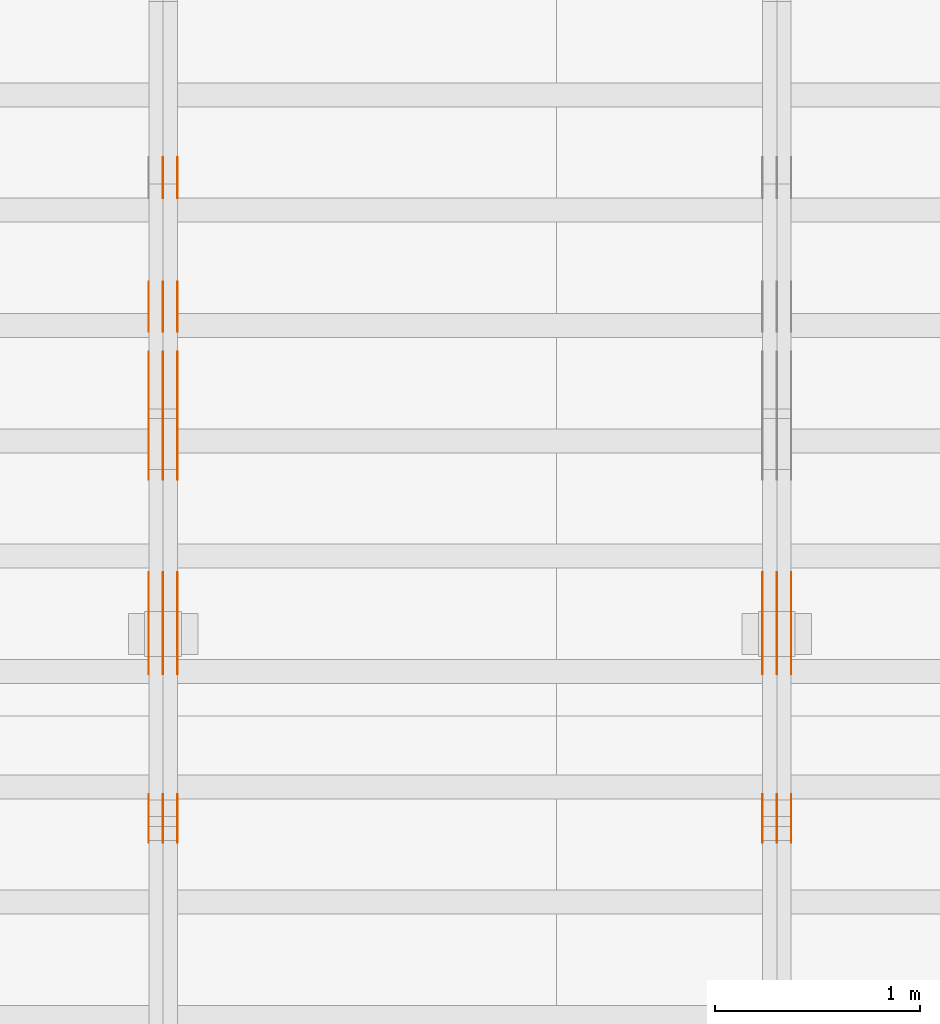
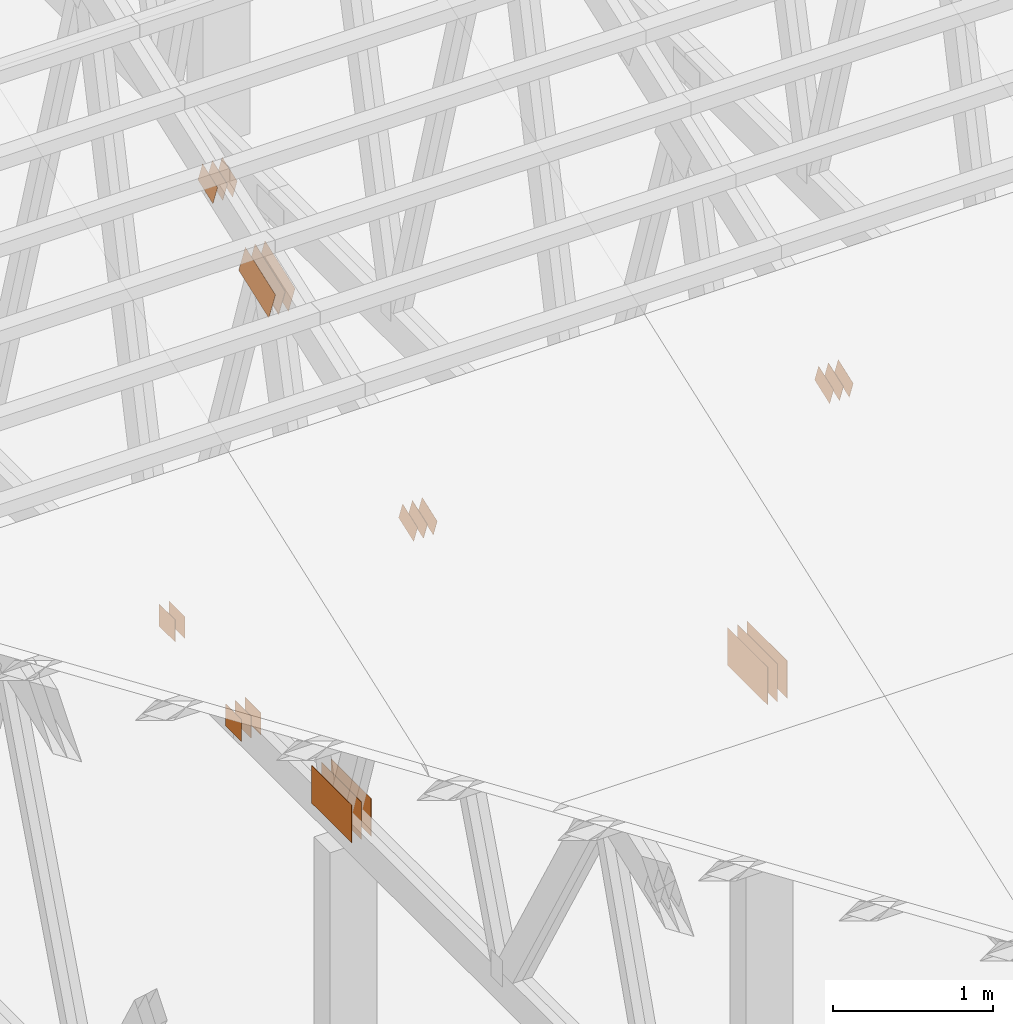
# One storey, part 95 of 189: 31 proxies.
"""IFC2X3 building model written with IfcOpenShell, lengths in millimetres."""

from ifc_helpers import new_model, entity, si_unit, converted_unit, derived_unit, direction, frame, frame_2d, origin, origin_2d_with_axis, place, context, subcontext, project, spatial, polyline, rectangle, outline, extrude, source, transform, mapped, material, type_object, type_shapes, element, save


model = new_model("IFC2X3")

# Units and contexts
model_context = context("Model", 3, precision=0.01, world=origin(), true_north=direction((6.12303176911189e-17, 1.0)))
body_context = subcontext(model_context, "Body", "Model", "MODEL_VIEW")
ifc_project = project(units=[si_unit("LENGTHUNIT", "METRE", prefix="MILLI"), si_unit("AREAUNIT", "SQUARE_METRE"), si_unit("VOLUMEUNIT", "CUBIC_METRE"), converted_unit("PLANEANGLEUNIT", "DEGREE", entity("IfcRatioMeasure", 0.0174532925199433), si_unit("PLANEANGLEUNIT", "RADIAN"), dimensions=[0, 0, 0, 0, 0, 0, 0]), si_unit("MASSUNIT", "GRAM", prefix="KILO"), derived_unit("MASSDENSITYUNIT", [(si_unit("MASSUNIT", "GRAM", prefix="KILO"), 1), (si_unit("LENGTHUNIT", "METRE"), -3)]), si_unit("TIMEUNIT", "SECOND"), si_unit("FREQUENCYUNIT", "HERTZ"), si_unit("THERMODYNAMICTEMPERATUREUNIT", "DEGREE_CELSIUS"), derived_unit("THERMALTRANSMITTANCEUNIT", [(si_unit("MASSUNIT", "GRAM", prefix="KILO"), 1), (si_unit("THERMODYNAMICTEMPERATUREUNIT", "KELVIN"), -1), (si_unit("TIMEUNIT", "SECOND"), -3)]), derived_unit("VOLUMETRICFLOWRATEUNIT", [(si_unit("LENGTHUNIT", "METRE"), 3), (si_unit("TIMEUNIT", "SECOND"), -1)]), si_unit("ELECTRICCURRENTUNIT", "AMPERE"), si_unit("ELECTRICVOLTAGEUNIT", "VOLT"), si_unit("POWERUNIT", "WATT"), si_unit("FORCEUNIT", "NEWTON"), si_unit("ILLUMINANCEUNIT", "LUX"), si_unit("LUMINOUSFLUXUNIT", "LUMEN"), si_unit("LUMINOUSINTENSITYUNIT", "CANDELA"), derived_unit("USERDEFINED", [(si_unit("MASSUNIT", "GRAM", prefix="KILO"), -1), (si_unit("LENGTHUNIT", "METRE"), -2), (si_unit("TIMEUNIT", "SECOND"), 3), (si_unit("LUMINOUSFLUXUNIT", "LUMEN"), 1)]), derived_unit("LINEARVELOCITYUNIT", [(si_unit("LENGTHUNIT", "METRE"), 1), (si_unit("TIMEUNIT", "SECOND"), -1)]), si_unit("PRESSUREUNIT", "PASCAL"), derived_unit("USERDEFINED", [(si_unit("LENGTHUNIT", "METRE"), -2), (si_unit("MASSUNIT", "GRAM", prefix="KILO"), 1), (si_unit("TIMEUNIT", "SECOND"), -2)])], contexts=[model_context])

# Site, building, storey
site_placement = place(None, origin())
site = spatial("IfcSite", under=ifc_project, at=site_placement, CompositionType="ELEMENT")
building_placement = place(site_placement, origin())
building = spatial("IfcBuilding", under=site, at=building_placement, CompositionType="ELEMENT")
storey_placement = place(building_placement, origin())
storey = spatial("IfcBuildingStorey", under=building, at=storey_placement, Name="Default", CompositionType="ELEMENT", Elevation=0.0)

# Proxies
ifc_material_1 = material(Name="IfcSurfaceStyle #107618")
building_element_proxy_type_1 = type_object("IfcBuildingElementProxyType", PredefinedType="NOTDEFINED", material=ifc_material_1)
shared_shape_1 = source(origin(), body_context, "Body", "SweptSolid", [
    extrude(rectangle(XDim=500.0, YDim=288.0, at=frame_2d((0.0, 1.4210854715202e-14), x_axis=(1.0, 0.0))), frame((250.000973740011, 144.0, 0.0), z_axis=(0.0, 0.0, 1.0), x_axis=(-1.0, 0.0, 0.0)), (0.0, 0.0, 1.0), 1.29999999999998),
])
type_shapes(building_element_proxy_type_1, [shared_shape_1])
proxy_1_placement = place(building_placement, frame((18301.3, 8551.90918250999, 389.0), z_axis=(-1.0, 0.0, 0.0), x_axis=(0.0, 1.0, 0.0)))
element("IfcBuildingElementProxy", 1, at=proxy_1_placement, inside=storey, type_object=building_element_proxy_type_1, material=ifc_material_1, context=body_context, shape_type="MappedRepresentation", body=[
    mapped(shared_shape_1, transform((0.0, 0.0, 0.0), scale=1.0)),
])
ifc_material_2 = material(Name="IfcSurfaceStyle #107561")
building_element_proxy_type_2 = type_object("IfcBuildingElementProxyType", PredefinedType="NOTDEFINED", material=ifc_material_2)
shared_shape_2 = source(origin(), body_context, "Body", "SweptSolid", [
    extrude(rectangle(XDim=500.0, YDim=288.0, at=frame_2d((0.0, 1.4210854715202e-14), x_axis=(1.0, 0.0))), frame((250.000973740011, 144.0, 0.0), z_axis=(0.0, 0.0, 1.0), x_axis=(-1.0, 0.0, 0.0)), (0.0, 0.0, 1.0), 1.29999999999997),
])
type_shapes(building_element_proxy_type_2, [shared_shape_2])
proxy_2_placement = place(building_placement, frame((18230.0, 8551.90918250999, 389.0), z_axis=(-1.0, 0.0, 0.0), x_axis=(0.0, 1.0, 0.0)))
element("IfcBuildingElementProxy", 2, at=proxy_2_placement, inside=storey, type_object=building_element_proxy_type_2, material=ifc_material_2, context=body_context, shape_type="MappedRepresentation", body=[
    mapped(shared_shape_2, transform((0.0, 0.0, 0.0), scale=1.0)),
])
ifc_material_3 = material(Name="IfcSurfaceStyle #107504")
building_element_proxy_type_3 = type_object("IfcBuildingElementProxyType", PredefinedType="NOTDEFINED", material=ifc_material_3)
shared_shape_3 = source(origin(), body_context, "Body", "SweptSolid", [
    extrude(rectangle(XDim=500.0, YDim=288.0, at=frame_2d((0.0, 1.4210854715202e-14), x_axis=(1.0, 0.0))), frame((250.000973740011, 144.0, 0.0), z_axis=(0.0, 0.0, 1.0), x_axis=(-1.0, 0.0, 0.0)), (0.0, 0.0, 1.0), 1.29999999999997),
])
type_shapes(building_element_proxy_type_3, [shared_shape_3])
proxy_3_placement = place(building_placement, frame((18231.3, 8551.90918250999, 389.0), z_axis=(-1.0, 0.0, 0.0), x_axis=(0.0, 1.0, 0.0)))
element("IfcBuildingElementProxy", 3, at=proxy_3_placement, inside=storey, type_object=building_element_proxy_type_3, material=ifc_material_3, context=body_context, shape_type="MappedRepresentation", body=[
    mapped(shared_shape_3, transform((0.0, 0.0, 0.0), scale=1.0)),
])
ifc_material_4 = material(Name="IfcSurfaceStyle #107447")
building_element_proxy_type_4 = type_object("IfcBuildingElementProxyType", PredefinedType="NOTDEFINED", material=ifc_material_4)
shared_shape_4 = source(origin(), body_context, "Body", "SweptSolid", [
    extrude(rectangle(XDim=500.0, YDim=288.0, at=frame_2d((0.0, 1.4210854715202e-14), x_axis=(1.0, 0.0))), frame((250.000973740011, 144.0, 0.0), z_axis=(0.0, 0.0, 1.0), x_axis=(-1.0, 0.0, 0.0)), (0.0, 0.0, 1.0), 1.29999999999997),
])
type_shapes(building_element_proxy_type_4, [shared_shape_4])
proxy_4_placement = place(building_placement, frame((18160.0, 8551.90918250999, 389.0), z_axis=(-1.0, 0.0, 0.0), x_axis=(0.0, 1.0, 0.0)))
element("IfcBuildingElementProxy", 4, at=proxy_4_placement, inside=storey, type_object=building_element_proxy_type_4, material=ifc_material_4, context=body_context, shape_type="MappedRepresentation", body=[
    mapped(shared_shape_4, transform((0.0, 0.0, 0.0), scale=1.0)),
])
ifc_material_5 = material(Name="IfcSurfaceStyle #107390")
building_element_proxy_type_5 = type_object("IfcBuildingElementProxyType", PredefinedType="NOTDEFINED", material=ifc_material_5)
shared_shape_5 = source(origin(), body_context, "Body", "SweptSolid", [
    extrude(outline(polyline([(-100.00048713087, -72.0000025659129), (100.000394045495, -72.0000025659129), (99.9995694622958, 72.0000025659129), (-99.9994763769209, 72.0000025659128), (-100.00048713087, -72.0000025659129)])), frame((100.000394045495, 72.0000025659128, 0.0), z_axis=(0.0, 0.0, 1.0), x_axis=(-1.0, 0.0, 0.0)), (0.0, 0.0, 1.0), 1.3),
])
type_shapes(building_element_proxy_type_5, [shared_shape_5])
proxy_5_placement = place(building_placement, frame((18301.3, 7965.16887114408, 2936.19963864386), z_axis=(-1.0, 0.0, 0.0), x_axis=(0.0, -0.939692620785908, -0.342020143325669)))
element("IfcBuildingElementProxy", 5, at=proxy_5_placement, inside=storey, type_object=building_element_proxy_type_5, material=ifc_material_5, context=body_context, shape_type="MappedRepresentation", body=[
    mapped(shared_shape_5, transform((0.0, 0.0, 0.0), scale=1.0)),
])
ifc_material_6 = material(Name="IfcSurfaceStyle #107333")
building_element_proxy_type_6 = type_object("IfcBuildingElementProxyType", PredefinedType="NOTDEFINED", material=ifc_material_6)
shared_shape_6 = source(origin(), body_context, "Body", "SweptSolid", [
    extrude(outline(polyline([(-100.00048713087, -72.0000025659129), (100.000394045495, -72.0000025659129), (99.9995694622958, 72.0000025659129), (-99.9994763769209, 72.0000025659128), (-100.00048713087, -72.0000025659129)])), frame((100.000394045495, 72.0000025659128, 0.0), z_axis=(0.0, 0.0, 1.0), x_axis=(-1.0, 0.0, 0.0)), (0.0, 0.0, 1.0), 1.29999999999998),
])
type_shapes(building_element_proxy_type_6, [shared_shape_6])
proxy_6_placement = place(building_placement, frame((18230.0, 7965.16887114408, 2936.19963864386), z_axis=(-1.0, 0.0, 0.0), x_axis=(0.0, -0.939692620785908, -0.342020143325669)))
element("IfcBuildingElementProxy", 6, at=proxy_6_placement, inside=storey, type_object=building_element_proxy_type_6, material=ifc_material_6, context=body_context, shape_type="MappedRepresentation", body=[
    mapped(shared_shape_6, transform((0.0, 0.0, 0.0), scale=1.0)),
])
ifc_material_7 = material(Name="IfcSurfaceStyle #107276")
building_element_proxy_type_7 = type_object("IfcBuildingElementProxyType", PredefinedType="NOTDEFINED", material=ifc_material_7)
shared_shape_7 = source(origin(), body_context, "Body", "SweptSolid", [
    extrude(outline(polyline([(-100.00048713087, -72.0000025659129), (100.000394045495, -72.0000025659129), (99.9995694622958, 72.0000025659129), (-99.9994763769209, 72.0000025659128), (-100.00048713087, -72.0000025659129)])), frame((100.000394045495, 72.0000025659128, 0.0), z_axis=(0.0, 0.0, 1.0), x_axis=(-1.0, 0.0, 0.0)), (0.0, 0.0, 1.0), 1.29999999999998),
])
type_shapes(building_element_proxy_type_7, [shared_shape_7])
proxy_7_placement = place(building_placement, frame((18231.3, 7965.16887114408, 2936.19963864386), z_axis=(-1.0, 0.0, 0.0), x_axis=(0.0, -0.939692620785908, -0.342020143325669)))
element("IfcBuildingElementProxy", 7, at=proxy_7_placement, inside=storey, type_object=building_element_proxy_type_7, material=ifc_material_7, context=body_context, shape_type="MappedRepresentation", body=[
    mapped(shared_shape_7, transform((0.0, 0.0, 0.0), scale=1.0)),
])
ifc_material_8 = material(Name="IfcSurfaceStyle #107219")
building_element_proxy_type_8 = type_object("IfcBuildingElementProxyType", PredefinedType="NOTDEFINED", material=ifc_material_8)
shared_shape_8 = source(origin(), body_context, "Body", "SweptSolid", [
    extrude(outline(polyline([(-100.00048713087, -72.0000025659129), (100.000394045495, -72.0000025659129), (99.9995694622958, 72.0000025659129), (-99.9994763769209, 72.0000025659128), (-100.00048713087, -72.0000025659129)])), frame((100.000394045495, 72.0000025659128, 0.0), z_axis=(0.0, 0.0, 1.0), x_axis=(-1.0, 0.0, 0.0)), (0.0, 0.0, 1.0), 1.29999999999999),
])
type_shapes(building_element_proxy_type_8, [shared_shape_8])
proxy_8_placement = place(building_placement, frame((18160.0, 7965.16887114408, 2936.19963864386), z_axis=(-1.0, 0.0, 0.0), x_axis=(0.0, -0.939692620785908, -0.342020143325669)))
element("IfcBuildingElementProxy", 8, at=proxy_8_placement, inside=storey, type_object=building_element_proxy_type_8, material=ifc_material_8, context=body_context, shape_type="MappedRepresentation", body=[
    mapped(shared_shape_8, transform((0.0, 0.0, 0.0), scale=1.0)),
])
ifc_material_9 = material(Name="IfcSurfaceStyle #92740")
building_element_proxy_type_9 = type_object("IfcBuildingElementProxyType", PredefinedType="NOTDEFINED", material=ifc_material_9)
shared_shape_9 = source(origin(), body_context, "Body", "SweptSolid", [
    extrude(rectangle(XDim=200.0, YDim=168.0, at=origin_2d_with_axis()), frame((100.000765376775, 84.0, 0.0), z_axis=(0.0, 0.0, 1.0), x_axis=(-1.0, 0.0, 0.0)), (0.0, 0.0, 1.0), 1.3),
])
type_shapes(building_element_proxy_type_9, [shared_shape_9])
proxy_9_placement = place(building_placement, frame((15301.3, 10880.1574377482, 365.0), z_axis=(-1.0, 0.0, 0.0), x_axis=(0.0, 1.0, 0.0)))
element("IfcBuildingElementProxy", 9, at=proxy_9_placement, inside=storey, type_object=building_element_proxy_type_9, material=ifc_material_9, context=body_context, shape_type="MappedRepresentation", body=[
    mapped(shared_shape_9, transform((0.0, 0.0, 0.0), scale=1.0)),
])
ifc_material_10 = material(Name="IfcSurfaceStyle #92683")
building_element_proxy_type_10 = type_object("IfcBuildingElementProxyType", PredefinedType="NOTDEFINED", material=ifc_material_10)
shared_shape_10 = source(origin(), body_context, "Body", "SweptSolid", [
    extrude(rectangle(XDim=200.0, YDim=168.0, at=origin_2d_with_axis()), frame((100.000765376775, 84.0, 0.0), z_axis=(0.0, 0.0, 1.0), x_axis=(-1.0, 0.0, 0.0)), (0.0, 0.0, 1.0), 1.29999999999998),
])
type_shapes(building_element_proxy_type_10, [shared_shape_10])
proxy_10_placement = place(building_placement, frame((15230.0, 10880.1574377482, 365.0), z_axis=(-1.0, 0.0, 0.0), x_axis=(0.0, 1.0, 0.0)))
element("IfcBuildingElementProxy", 10, at=proxy_10_placement, inside=storey, type_object=building_element_proxy_type_10, material=ifc_material_10, context=body_context, shape_type="MappedRepresentation", body=[
    mapped(shared_shape_10, transform((0.0, 0.0, 0.0), scale=1.0)),
])
ifc_material_11 = material(Name="IfcSurfaceStyle #92626")
building_element_proxy_type_11 = type_object("IfcBuildingElementProxyType", PredefinedType="NOTDEFINED", material=ifc_material_11)
shared_shape_11 = source(origin(), body_context, "Body", "SweptSolid", [
    extrude(rectangle(XDim=200.0, YDim=168.0, at=origin_2d_with_axis()), frame((100.000765376775, 84.0, 0.0), z_axis=(0.0, 0.0, 1.0), x_axis=(-1.0, 0.0, 0.0)), (0.0, 0.0, 1.0), 1.29999999999998),
])
type_shapes(building_element_proxy_type_11, [shared_shape_11])
proxy_11_placement = place(building_placement, frame((15231.3, 10880.1574377482, 365.0), z_axis=(-1.0, 0.0, 0.0), x_axis=(0.0, 1.0, 0.0)))
element("IfcBuildingElementProxy", 11, at=proxy_11_placement, inside=storey, type_object=building_element_proxy_type_11, material=ifc_material_11, context=body_context, shape_type="MappedRepresentation", body=[
    mapped(shared_shape_11, transform((0.0, 0.0, 0.0), scale=1.0)),
])
ifc_material_12 = material(Name="IfcSurfaceStyle #92512")
building_element_proxy_type_12 = type_object("IfcBuildingElementProxyType", PredefinedType="NOTDEFINED", material=ifc_material_12)
shared_shape_12 = source(origin(), body_context, "Body", "SweptSolid", [
    extrude(outline(polyline([(-199.999582244654, -119.99984375717), (200.000344770932, -119.99984375717), (199.999582244655, 119.99984375717), (-200.000344770934, 119.99984375717), (-199.999582244654, -119.99984375717)])), frame((200.000344770932, 120.0000091947, 0.0), z_axis=(0.0, 0.0, 1.0), x_axis=(-1.0, 0.0, 0.0)), (0.0, 0.0, 1.0), 1.29999999999999),
])
type_shapes(building_element_proxy_type_12, [shared_shape_12])
proxy_12_placement = place(building_placement, frame((15301.3, 9961.90704972973, 3612.2451494258), z_axis=(-1.0, 0.0, 0.0), x_axis=(0.0, -0.939692620785908, -0.342020143325669)))
element("IfcBuildingElementProxy", 12, at=proxy_12_placement, inside=storey, type_object=building_element_proxy_type_12, material=ifc_material_12, context=body_context, shape_type="MappedRepresentation", body=[
    mapped(shared_shape_12, transform((0.0, 0.0, 0.0), scale=1.0)),
])
ifc_material_13 = material(Name="IfcSurfaceStyle #92455")
building_element_proxy_type_13 = type_object("IfcBuildingElementProxyType", PredefinedType="NOTDEFINED", material=ifc_material_13)
shared_shape_13 = source(origin(), body_context, "Body", "SweptSolid", [
    extrude(outline(polyline([(-199.999582244654, -119.99984375717), (200.000344770932, -119.99984375717), (199.999582244655, 119.99984375717), (-200.000344770934, 119.99984375717), (-199.999582244654, -119.99984375717)])), frame((200.000344770932, 120.0000091947, 0.0), z_axis=(0.0, 0.0, 1.0), x_axis=(-1.0, 0.0, 0.0)), (0.0, 0.0, 1.0), 1.29999999999997),
])
type_shapes(building_element_proxy_type_13, [shared_shape_13])
proxy_13_placement = place(building_placement, frame((15230.0, 9961.90704972973, 3612.2451494258), z_axis=(-1.0, 0.0, 0.0), x_axis=(0.0, -0.939692620785908, -0.342020143325669)))
element("IfcBuildingElementProxy", 13, at=proxy_13_placement, inside=storey, type_object=building_element_proxy_type_13, material=ifc_material_13, context=body_context, shape_type="MappedRepresentation", body=[
    mapped(shared_shape_13, transform((0.0, 0.0, 0.0), scale=1.0)),
])
ifc_material_14 = material(Name="IfcSurfaceStyle #92398")
building_element_proxy_type_14 = type_object("IfcBuildingElementProxyType", PredefinedType="NOTDEFINED", material=ifc_material_14)
shared_shape_14 = source(origin(), body_context, "Body", "SweptSolid", [
    extrude(outline(polyline([(-199.999582244654, -119.99984375717), (200.000344770932, -119.99984375717), (199.999582244655, 119.99984375717), (-200.000344770934, 119.99984375717), (-199.999582244654, -119.99984375717)])), frame((200.000344770932, 120.0000091947, 0.0), z_axis=(0.0, 0.0, 1.0), x_axis=(-1.0, 0.0, 0.0)), (0.0, 0.0, 1.0), 1.29999999999997),
])
type_shapes(building_element_proxy_type_14, [shared_shape_14])
proxy_14_placement = place(building_placement, frame((15231.3, 9961.90704972973, 3612.2451494258), z_axis=(-1.0, 0.0, 0.0), x_axis=(0.0, -0.939692620785908, -0.342020143325669)))
element("IfcBuildingElementProxy", 14, at=proxy_14_placement, inside=storey, type_object=building_element_proxy_type_14, material=ifc_material_14, context=body_context, shape_type="MappedRepresentation", body=[
    mapped(shared_shape_14, transform((0.0, 0.0, 0.0), scale=1.0)),
])
ifc_material_15 = material(Name="IfcSurfaceStyle #92341")
building_element_proxy_type_15 = type_object("IfcBuildingElementProxyType", PredefinedType="NOTDEFINED", material=ifc_material_15)
shared_shape_15 = source(origin(), body_context, "Body", "SweptSolid", [
    extrude(outline(polyline([(-199.999582244654, -119.99984375717), (200.000344770932, -119.99984375717), (199.999582244655, 119.99984375717), (-200.000344770934, 119.99984375717), (-199.999582244654, -119.99984375717)])), frame((200.000344770932, 120.0000091947, 0.0), z_axis=(0.0, 0.0, 1.0), x_axis=(-1.0, 0.0, 0.0)), (0.0, 0.0, 1.0), 1.29999999999998),
])
type_shapes(building_element_proxy_type_15, [shared_shape_15])
proxy_15_placement = place(building_placement, frame((15160.0, 9961.90704972973, 3612.2451494258), z_axis=(-1.0, 0.0, 0.0), x_axis=(0.0, -0.939692620785908, -0.342020143325669)))
element("IfcBuildingElementProxy", 15, at=proxy_15_placement, inside=storey, type_object=building_element_proxy_type_15, material=ifc_material_15, context=body_context, shape_type="MappedRepresentation", body=[
    mapped(shared_shape_15, transform((0.0, 0.0, 0.0), scale=1.0)),
])
ifc_material_16 = material(Name="IfcSurfaceStyle #91828")
building_element_proxy_type_16 = type_object("IfcBuildingElementProxyType", PredefinedType="NOTDEFINED", material=ifc_material_16)
shared_shape_16 = source(origin(), body_context, "Body", "SweptSolid", [
    extrude(rectangle(XDim=500.0, YDim=288.0, at=frame_2d((0.0, 1.4210854715202e-14), x_axis=(1.0, 0.0))), frame((250.000973740011, 144.0, 0.0), z_axis=(0.0, 0.0, 1.0), x_axis=(-1.0, 0.0, 0.0)), (0.0, 0.0, 1.0), 1.29999999999998),
])
type_shapes(building_element_proxy_type_16, [shared_shape_16])
proxy_16_placement = place(building_placement, frame((15301.3, 8551.90918250999, 389.0), z_axis=(-1.0, 0.0, 0.0), x_axis=(0.0, 1.0, 0.0)))
element("IfcBuildingElementProxy", 16, at=proxy_16_placement, inside=storey, type_object=building_element_proxy_type_16, material=ifc_material_16, context=body_context, shape_type="MappedRepresentation", body=[
    mapped(shared_shape_16, transform((0.0, 0.0, 0.0), scale=1.0)),
])
ifc_material_17 = material(Name="IfcSurfaceStyle #91771")
building_element_proxy_type_17 = type_object("IfcBuildingElementProxyType", PredefinedType="NOTDEFINED", material=ifc_material_17)
shared_shape_17 = source(origin(), body_context, "Body", "SweptSolid", [
    extrude(rectangle(XDim=500.0, YDim=288.0, at=frame_2d((0.0, 1.4210854715202e-14), x_axis=(1.0, 0.0))), frame((250.000973740011, 144.0, 0.0), z_axis=(0.0, 0.0, 1.0), x_axis=(-1.0, 0.0, 0.0)), (0.0, 0.0, 1.0), 1.29999999999997),
])
type_shapes(building_element_proxy_type_17, [shared_shape_17])
proxy_17_placement = place(building_placement, frame((15230.0, 8551.90918250999, 389.0), z_axis=(-1.0, 0.0, 0.0), x_axis=(0.0, 1.0, 0.0)))
element("IfcBuildingElementProxy", 17, at=proxy_17_placement, inside=storey, type_object=building_element_proxy_type_17, material=ifc_material_17, context=body_context, shape_type="MappedRepresentation", body=[
    mapped(shared_shape_17, transform((0.0, 0.0, 0.0), scale=1.0)),
])
ifc_material_18 = material(Name="IfcSurfaceStyle #91714")
building_element_proxy_type_18 = type_object("IfcBuildingElementProxyType", PredefinedType="NOTDEFINED", material=ifc_material_18)
shared_shape_18 = source(origin(), body_context, "Body", "SweptSolid", [
    extrude(rectangle(XDim=500.0, YDim=288.0, at=frame_2d((0.0, 1.4210854715202e-14), x_axis=(1.0, 0.0))), frame((250.000973740011, 144.0, 0.0), z_axis=(0.0, 0.0, 1.0), x_axis=(-1.0, 0.0, 0.0)), (0.0, 0.0, 1.0), 1.29999999999997),
])
type_shapes(building_element_proxy_type_18, [shared_shape_18])
proxy_18_placement = place(building_placement, frame((15231.3, 8551.90918250999, 389.0), z_axis=(-1.0, 0.0, 0.0), x_axis=(0.0, 1.0, 0.0)))
element("IfcBuildingElementProxy", 18, at=proxy_18_placement, inside=storey, type_object=building_element_proxy_type_18, material=ifc_material_18, context=body_context, shape_type="MappedRepresentation", body=[
    mapped(shared_shape_18, transform((0.0, 0.0, 0.0), scale=1.0)),
])
ifc_material_19 = material(Name="IfcSurfaceStyle #91657")
building_element_proxy_type_19 = type_object("IfcBuildingElementProxyType", PredefinedType="NOTDEFINED", material=ifc_material_19)
shared_shape_19 = source(origin(), body_context, "Body", "SweptSolid", [
    extrude(rectangle(XDim=500.0, YDim=288.0, at=frame_2d((0.0, 1.4210854715202e-14), x_axis=(1.0, 0.0))), frame((250.000973740011, 144.0, 0.0), z_axis=(0.0, 0.0, 1.0), x_axis=(-1.0, 0.0, 0.0)), (0.0, 0.0, 1.0), 1.29999999999997),
])
type_shapes(building_element_proxy_type_19, [shared_shape_19])
proxy_19_placement = place(building_placement, frame((15160.0, 8551.90918250999, 389.0), z_axis=(-1.0, 0.0, 0.0), x_axis=(0.0, 1.0, 0.0)))
element("IfcBuildingElementProxy", 19, at=proxy_19_placement, inside=storey, type_object=building_element_proxy_type_19, material=ifc_material_19, context=body_context, shape_type="MappedRepresentation", body=[
    mapped(shared_shape_19, transform((0.0, 0.0, 0.0), scale=1.0)),
])
ifc_material_20 = material(Name="IfcSurfaceStyle #91600")
building_element_proxy_type_20 = type_object("IfcBuildingElementProxyType", PredefinedType="NOTDEFINED", material=ifc_material_20)
shared_shape_20 = source(origin(), body_context, "Body", "SweptSolid", [
    extrude(outline(polyline([(-100.00048713087, -72.0000025659129), (100.000394045495, -72.0000025659129), (99.9995694622958, 72.0000025659129), (-99.9994763769209, 72.0000025659128), (-100.00048713087, -72.0000025659129)])), frame((100.000394045495, 72.0000025659128, 0.0), z_axis=(0.0, 0.0, 1.0), x_axis=(-1.0, 0.0, 0.0)), (0.0, 0.0, 1.0), 1.3),
])
type_shapes(building_element_proxy_type_20, [shared_shape_20])
proxy_20_placement = place(building_placement, frame((15301.3, 7965.16887114408, 2936.19963864386), z_axis=(-1.0, 0.0, 0.0), x_axis=(0.0, -0.939692620785908, -0.342020143325669)))
element("IfcBuildingElementProxy", 20, at=proxy_20_placement, inside=storey, type_object=building_element_proxy_type_20, material=ifc_material_20, context=body_context, shape_type="MappedRepresentation", body=[
    mapped(shared_shape_20, transform((0.0, 0.0, 0.0), scale=1.0)),
])
ifc_material_21 = material(Name="IfcSurfaceStyle #91543")
building_element_proxy_type_21 = type_object("IfcBuildingElementProxyType", PredefinedType="NOTDEFINED", material=ifc_material_21)
shared_shape_21 = source(origin(), body_context, "Body", "SweptSolid", [
    extrude(outline(polyline([(-100.00048713087, -72.0000025659129), (100.000394045495, -72.0000025659129), (99.9995694622958, 72.0000025659129), (-99.9994763769209, 72.0000025659128), (-100.00048713087, -72.0000025659129)])), frame((100.000394045495, 72.0000025659128, 0.0), z_axis=(0.0, 0.0, 1.0), x_axis=(-1.0, 0.0, 0.0)), (0.0, 0.0, 1.0), 1.29999999999998),
])
type_shapes(building_element_proxy_type_21, [shared_shape_21])
proxy_21_placement = place(building_placement, frame((15230.0, 7965.16887114408, 2936.19963864386), z_axis=(-1.0, 0.0, 0.0), x_axis=(0.0, -0.939692620785908, -0.342020143325669)))
element("IfcBuildingElementProxy", 21, at=proxy_21_placement, inside=storey, type_object=building_element_proxy_type_21, material=ifc_material_21, context=body_context, shape_type="MappedRepresentation", body=[
    mapped(shared_shape_21, transform((0.0, 0.0, 0.0), scale=1.0)),
])
ifc_material_22 = material(Name="IfcSurfaceStyle #91486")
building_element_proxy_type_22 = type_object("IfcBuildingElementProxyType", PredefinedType="NOTDEFINED", material=ifc_material_22)
shared_shape_22 = source(origin(), body_context, "Body", "SweptSolid", [
    extrude(outline(polyline([(-100.00048713087, -72.0000025659129), (100.000394045495, -72.0000025659129), (99.9995694622958, 72.0000025659129), (-99.9994763769209, 72.0000025659128), (-100.00048713087, -72.0000025659129)])), frame((100.000394045495, 72.0000025659128, 0.0), z_axis=(0.0, 0.0, 1.0), x_axis=(-1.0, 0.0, 0.0)), (0.0, 0.0, 1.0), 1.29999999999998),
])
type_shapes(building_element_proxy_type_22, [shared_shape_22])
proxy_22_placement = place(building_placement, frame((15231.3, 7965.16887114408, 2936.19963864386), z_axis=(-1.0, 0.0, 0.0), x_axis=(0.0, -0.939692620785908, -0.342020143325669)))
element("IfcBuildingElementProxy", 22, at=proxy_22_placement, inside=storey, type_object=building_element_proxy_type_22, material=ifc_material_22, context=body_context, shape_type="MappedRepresentation", body=[
    mapped(shared_shape_22, transform((0.0, 0.0, 0.0), scale=1.0)),
])
ifc_material_23 = material(Name="IfcSurfaceStyle #91429")
building_element_proxy_type_23 = type_object("IfcBuildingElementProxyType", PredefinedType="NOTDEFINED", material=ifc_material_23)
shared_shape_23 = source(origin(), body_context, "Body", "SweptSolid", [
    extrude(outline(polyline([(-100.00048713087, -72.0000025659129), (100.000394045495, -72.0000025659129), (99.9995694622958, 72.0000025659129), (-99.9994763769209, 72.0000025659128), (-100.00048713087, -72.0000025659129)])), frame((100.000394045495, 72.0000025659128, 0.0), z_axis=(0.0, 0.0, 1.0), x_axis=(-1.0, 0.0, 0.0)), (0.0, 0.0, 1.0), 1.29999999999999),
])
type_shapes(building_element_proxy_type_23, [shared_shape_23])
proxy_23_placement = place(building_placement, frame((15160.0, 7965.16887114408, 2936.19963864386), z_axis=(-1.0, 0.0, 0.0), x_axis=(0.0, -0.939692620785908, -0.342020143325669)))
element("IfcBuildingElementProxy", 23, at=proxy_23_placement, inside=storey, type_object=building_element_proxy_type_23, material=ifc_material_23, context=body_context, shape_type="MappedRepresentation", body=[
    mapped(shared_shape_23, transform((0.0, 0.0, 0.0), scale=1.0)),
])
ifc_material_24 = material(Name="IfcSurfaceStyle #86188")
building_element_proxy_type_24 = type_object("IfcBuildingElementProxyType", PredefinedType="NOTDEFINED", material=ifc_material_24)
shared_shape_24 = source(origin(), body_context, "Body", "SweptSolid", [
    extrude(rectangle(XDim=200.0, YDim=168.0, at=origin_2d_with_axis()), frame((100.0, 84.0, 0.0), z_axis=(0.0, 0.0, 1.0), x_axis=(-1.0, 0.0, 0.0)), (0.0, 0.0, 1.0), 1.3),
])
type_shapes(building_element_proxy_type_24, [shared_shape_24])
proxy_24_placement = place(building_placement, frame((15301.3, 9929.23046875, 206.5), z_axis=(-1.0, 0.0, 0.0), x_axis=(0.0, 1.0, 0.0)))
element("IfcBuildingElementProxy", 24, at=proxy_24_placement, inside=storey, type_object=building_element_proxy_type_24, material=ifc_material_24, context=body_context, shape_type="MappedRepresentation", body=[
    mapped(shared_shape_24, transform((0.0, 0.0, 0.0), scale=1.0)),
])
ifc_material_25 = material(Name="IfcSurfaceStyle #86131")
building_element_proxy_type_25 = type_object("IfcBuildingElementProxyType", PredefinedType="NOTDEFINED", material=ifc_material_25)
shared_shape_25 = source(origin(), body_context, "Body", "SweptSolid", [
    extrude(rectangle(XDim=200.0, YDim=168.0, at=origin_2d_with_axis()), frame((100.0, 84.0, 0.0), z_axis=(0.0, 0.0, 1.0), x_axis=(-1.0, 0.0, 0.0)), (0.0, 0.0, 1.0), 1.29999999999998),
])
type_shapes(building_element_proxy_type_25, [shared_shape_25])
proxy_25_placement = place(building_placement, frame((15230.0, 9929.23046875, 206.5), z_axis=(-1.0, 0.0, 0.0), x_axis=(0.0, 1.0, 0.0)))
element("IfcBuildingElementProxy", 25, at=proxy_25_placement, inside=storey, type_object=building_element_proxy_type_25, material=ifc_material_25, context=body_context, shape_type="MappedRepresentation", body=[
    mapped(shared_shape_25, transform((0.0, 0.0, 0.0), scale=1.0)),
])
ifc_material_26 = material(Name="IfcSurfaceStyle #86074")
building_element_proxy_type_26 = type_object("IfcBuildingElementProxyType", PredefinedType="NOTDEFINED", material=ifc_material_26)
shared_shape_26 = source(origin(), body_context, "Body", "SweptSolid", [
    extrude(rectangle(XDim=200.0, YDim=168.0, at=origin_2d_with_axis()), frame((100.0, 84.0, 0.0), z_axis=(0.0, 0.0, 1.0), x_axis=(-1.0, 0.0, 0.0)), (0.0, 0.0, 1.0), 1.29999999999998),
])
type_shapes(building_element_proxy_type_26, [shared_shape_26])
proxy_26_placement = place(building_placement, frame((15231.3, 9929.23046875, 206.5), z_axis=(-1.0, 0.0, 0.0), x_axis=(0.0, 1.0, 0.0)))
element("IfcBuildingElementProxy", 26, at=proxy_26_placement, inside=storey, type_object=building_element_proxy_type_26, material=ifc_material_26, context=body_context, shape_type="MappedRepresentation", body=[
    mapped(shared_shape_26, transform((0.0, 0.0, 0.0), scale=1.0)),
])
ifc_material_27 = material(Name="IfcSurfaceStyle #86017")
building_element_proxy_type_27 = type_object("IfcBuildingElementProxyType", PredefinedType="NOTDEFINED", material=ifc_material_27)
shared_shape_27 = source(origin(), body_context, "Body", "SweptSolid", [
    extrude(rectangle(XDim=200.0, YDim=168.0, at=origin_2d_with_axis()), frame((100.0, 84.0, 0.0), z_axis=(0.0, 0.0, 1.0), x_axis=(-1.0, 0.0, 0.0)), (0.0, 0.0, 1.0), 1.29999999999999),
])
type_shapes(building_element_proxy_type_27, [shared_shape_27])
proxy_27_placement = place(building_placement, frame((15160.0, 9929.23046875, 206.5), z_axis=(-1.0, 0.0, 0.0), x_axis=(0.0, 1.0, 0.0)))
element("IfcBuildingElementProxy", 27, at=proxy_27_placement, inside=storey, type_object=building_element_proxy_type_27, material=ifc_material_27, context=body_context, shape_type="MappedRepresentation", body=[
    mapped(shared_shape_27, transform((0.0, 0.0, 0.0), scale=1.0)),
])
ifc_material_28 = material(Name="IfcSurfaceStyle #85108")
building_element_proxy_type_28 = type_object("IfcBuildingElementProxyType", PredefinedType="NOTDEFINED", material=ifc_material_28)
shared_shape_28 = source(origin(), body_context, "Body", "SweptSolid", [
    extrude(outline(polyline([(-100.00072430513, -84.0000258989549), (100.000156871239, -84.0000258989549), (99.9997648860508, 84.0000258989549), (-99.9991974521591, 84.0000258989548), (-100.00072430513, -84.0000258989549)])), frame((100.000156871239, 84.0000258989548, 0.0), z_axis=(0.0, 0.0, 1.0), x_axis=(-1.0, 0.0, 0.0)), (0.0, 0.0, 1.0), 1.3),
])
type_shapes(building_element_proxy_type_28, [shared_shape_28])
proxy_28_placement = place(building_placement, frame((15301.3, 10226.4409888304, 4081.14941482552), z_axis=(-1.0, 0.0, 0.0), x_axis=(0.0, 0.939692620785908, 0.342020143325669)))
element("IfcBuildingElementProxy", 28, at=proxy_28_placement, inside=storey, type_object=building_element_proxy_type_28, material=ifc_material_28, context=body_context, shape_type="MappedRepresentation", body=[
    mapped(shared_shape_28, transform((0.0, 0.0, 0.0), scale=1.0)),
])
ifc_material_29 = material(Name="IfcSurfaceStyle #85051")
building_element_proxy_type_29 = type_object("IfcBuildingElementProxyType", PredefinedType="NOTDEFINED", material=ifc_material_29)
shared_shape_29 = source(origin(), body_context, "Body", "SweptSolid", [
    extrude(outline(polyline([(-100.00072430513, -84.0000258989549), (100.000156871239, -84.0000258989549), (99.9997648860508, 84.0000258989549), (-99.9991974521591, 84.0000258989548), (-100.00072430513, -84.0000258989549)])), frame((100.000156871239, 84.0000258989548, 0.0), z_axis=(0.0, 0.0, 1.0), x_axis=(-1.0, 0.0, 0.0)), (0.0, 0.0, 1.0), 1.29999999999998),
])
type_shapes(building_element_proxy_type_29, [shared_shape_29])
proxy_29_placement = place(building_placement, frame((15230.0, 10226.4409888304, 4081.14941482552), z_axis=(-1.0, 0.0, 0.0), x_axis=(0.0, 0.939692620785908, 0.342020143325669)))
element("IfcBuildingElementProxy", 29, at=proxy_29_placement, inside=storey, type_object=building_element_proxy_type_29, material=ifc_material_29, context=body_context, shape_type="MappedRepresentation", body=[
    mapped(shared_shape_29, transform((0.0, 0.0, 0.0), scale=1.0)),
])
ifc_material_30 = material(Name="IfcSurfaceStyle #84994")
building_element_proxy_type_30 = type_object("IfcBuildingElementProxyType", PredefinedType="NOTDEFINED", material=ifc_material_30)
shared_shape_30 = source(origin(), body_context, "Body", "SweptSolid", [
    extrude(outline(polyline([(-100.00072430513, -84.0000258989549), (100.000156871239, -84.0000258989549), (99.9997648860508, 84.0000258989549), (-99.9991974521591, 84.0000258989548), (-100.00072430513, -84.0000258989549)])), frame((100.000156871239, 84.0000258989548, 0.0), z_axis=(0.0, 0.0, 1.0), x_axis=(-1.0, 0.0, 0.0)), (0.0, 0.0, 1.0), 1.29999999999998),
])
type_shapes(building_element_proxy_type_30, [shared_shape_30])
proxy_30_placement = place(building_placement, frame((15231.3, 10226.4409888304, 4081.14941482552), z_axis=(-1.0, 0.0, 0.0), x_axis=(0.0, 0.939692620785908, 0.342020143325669)))
element("IfcBuildingElementProxy", 30, at=proxy_30_placement, inside=storey, type_object=building_element_proxy_type_30, material=ifc_material_30, context=body_context, shape_type="MappedRepresentation", body=[
    mapped(shared_shape_30, transform((0.0, 0.0, 0.0), scale=1.0)),
])
ifc_material_31 = material(Name="IfcSurfaceStyle #84937")
building_element_proxy_type_31 = type_object("IfcBuildingElementProxyType", PredefinedType="NOTDEFINED", material=ifc_material_31)
shared_shape_31 = source(origin(), body_context, "Body", "SweptSolid", [
    extrude(outline(polyline([(-100.00072430513, -84.0000258989549), (100.000156871239, -84.0000258989549), (99.9997648860508, 84.0000258989549), (-99.9991974521591, 84.0000258989548), (-100.00072430513, -84.0000258989549)])), frame((100.000156871239, 84.0000258989548, 0.0), z_axis=(0.0, 0.0, 1.0), x_axis=(-1.0, 0.0, 0.0)), (0.0, 0.0, 1.0), 1.29999999999999),
])
type_shapes(building_element_proxy_type_31, [shared_shape_31])
proxy_31_placement = place(building_placement, frame((15160.0, 10226.4409888304, 4081.14941482552), z_axis=(-1.0, 0.0, 0.0), x_axis=(0.0, 0.939692620785908, 0.342020143325669)))
element("IfcBuildingElementProxy", 31, at=proxy_31_placement, inside=storey, type_object=building_element_proxy_type_31, material=ifc_material_31, context=body_context, shape_type="MappedRepresentation", body=[
    mapped(shared_shape_31, transform((0.0, 0.0, 0.0), scale=1.0)),
])

save(model, "model.ifc")
